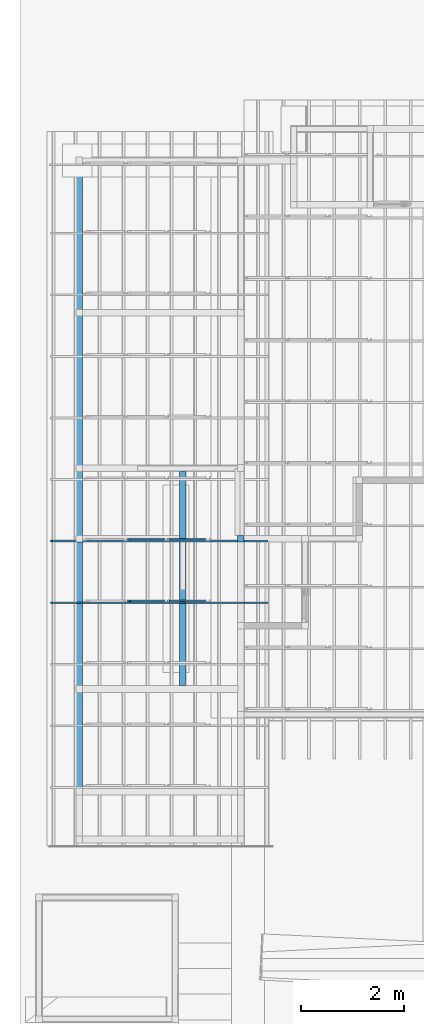
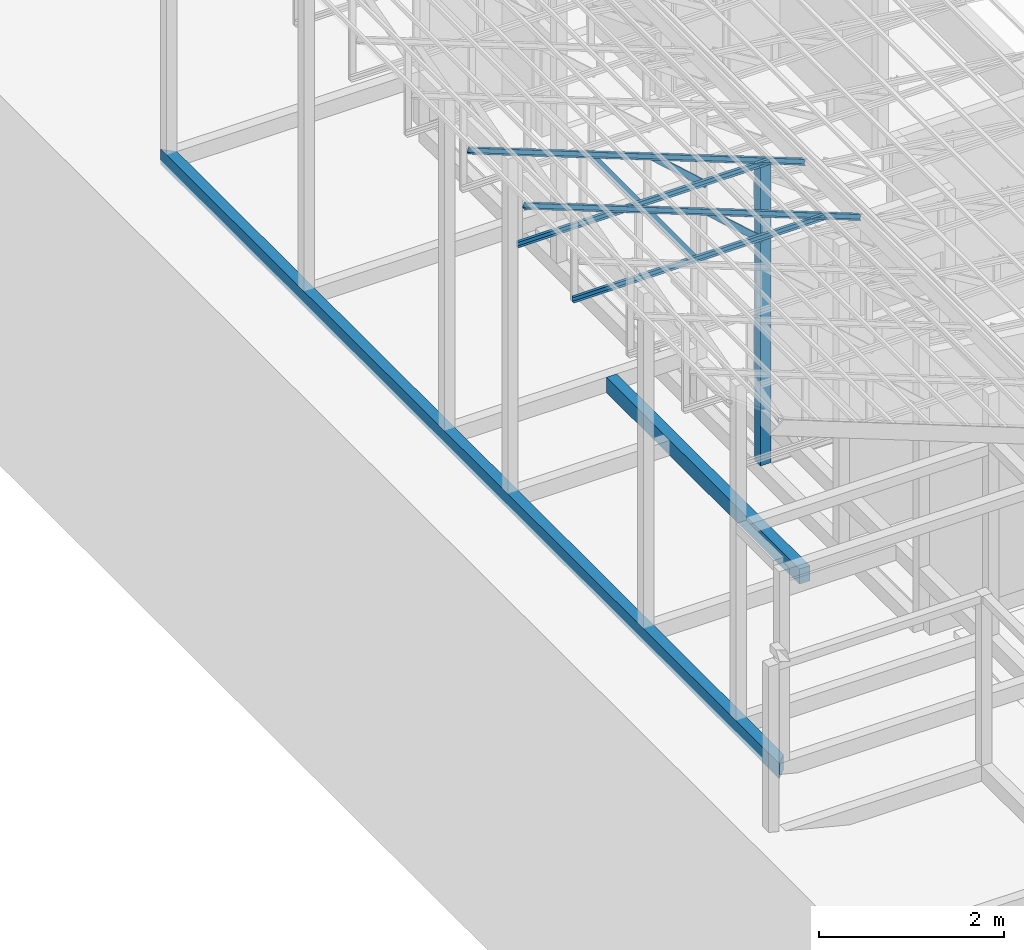
# One storey, part 7 of 22: 8 members, 3 beams, 1 element without a shape of its own.
"""IFC4 building model written with IfcOpenShell, lengths in millimetres."""

from ifc_helpers import new_model, entity, si_unit, converted_unit, frame, origin_with_axes, origin_2d_with_axis, place, context, subcontext, project, spatial, indexed_curve, rectangle, c_section, outline, extrude, clip, halfspace, material, material_profile, profile_set, profile_usage, type_object, element, aggregate, save


model = new_model("IFC4")

# Units and contexts
model_context = context("Model", 3, precision=1e-05, world=origin_with_axes())
plan_context = context("Plan", 2, precision=1e-05, world=origin_2d_with_axis())
body_context = subcontext(model_context, "Body", "Model", "MODEL_VIEW")
ifc_project = project(units=[si_unit("VOLUMEUNIT", "CUBIC_METRE"), si_unit("LENGTHUNIT", "METRE", prefix="MILLI"), si_unit("AREAUNIT", "SQUARE_METRE"), converted_unit("PLANEANGLEUNIT", "degree", entity("IfcReal", 0.0174532925199433), si_unit("PLANEANGLEUNIT", "RADIAN"), dimensions=[0, 0, 0, 0, 0, 0, 0])], contexts=[model_context, plan_context])

# Site, building, storey
site_placement = place(None, origin_with_axes())
site = spatial("IfcSite", under=ifc_project, at=site_placement)
building_placement = place(site_placement, origin_with_axes())
building = spatial("IfcBuilding", under=site, at=building_placement, Name="2")
storey_placement = place(building_placement, frame((0.0, 0.0, 200.000002980232), z_axis=(0.0, 0.0, 1.0), x_axis=(1.0, 0.0, 0.0)))
storey = spatial("IfcBuildingStorey", under=building, at=storey_placement)

# Beams
ifc_material_1 = material(Name="Concrete")
ifc_material_profile_1 = material_profile(ifc_material_1, outline(indexed_curve([(-65.0, 99.9999923706055), (65.0, 99.9999923706055), (65.0, -99.9999923706055), (-65.0, -99.9999923706055), (-65.0, 99.9999923706055)])))
ifc_profile_set_1 = profile_set([ifc_material_profile_1])
ifc_profile_usage_1 = profile_usage(ifc_profile_set_1, cardinal=2)
beam_type_1 = type_object("IfcBeamType", PredefinedType="BEAM", material=ifc_profile_set_1)
beam_1_placement = place(storey_placement, frame((-7149.99485015869, 17365.0016784668, 535.004422068596), z_axis=(-4.03943602122987e-07, -0.999999999999879, -2.82129974493694e-07), x_axis=(0.999999999999919, -4.03943602123003e-07, -2.79054360727867e-14)))
element("IfcBeam", 1, at=beam_1_placement, inside=storey, type_object=beam_type_1, material=ifc_profile_usage_1, Name="Beam", PredefinedType="BEAM", context=body_context, shape_type="Clipping", body=[
    clip(clip(extrude(outline(indexed_curve([(-65.0, 99.9999923706055), (65.0, 99.9999923706055), (65.0, -99.9999923706055), (-65.0, -99.9999923706055), (-65.0, 99.9999923706055)])), frame((0.0, 100.0, 0.0), z_axis=(0.0, 0.0, 1.0), x_axis=(1.0, 0.0, 0.0)), (0.0, 0.0, 1.0), 13364.9967612333), halfspace(frame((-65.0002434849739, -735.001146793365, 13364.9959564209), z_axis=(0.707107067108154, 2.83789603372497e-07, 0.707106471061707), x_axis=(4.01338943666742e-07, -0.99999999999992, 0.0)), False)), halfspace(frame((-64.9999156594276, -735.005497932434, 0.00100710269634874), z_axis=(0.707109093666077, -2.41642055698321e-07, -0.707104444503784), x_axis=(-3.41732354827301e-07, -0.999999999999942, 0.0)), False)),
])
ifc_profile_usage_2 = profile_usage(ifc_profile_set_1, cardinal=3)
beam_2_placement = place(storey_placement, frame((-5064.99624252319, 7065.00005722046, 535.004422068596), z_axis=(3.89414367418746e-07, 0.999999999999875, 3.13916473260139e-07), x_axis=(-0.999999999999924, 3.89414367418765e-07, -7.40532613008271e-09)))
element("IfcBeam", 2, at=beam_2_placement, inside=storey, type_object=beam_type_1, material=ifc_profile_usage_2, Name="Beam", PredefinedType="BEAM", context=body_context, shape_type="SweptSolid", body=[
    extrude(outline(indexed_curve([(-65.0, 99.9999923706055), (65.0, 99.9999923706055), (65.0, -99.9999923706055), (-65.0, -99.9999923706055), (-65.0, 99.9999923706055)])), frame((65.0, 99.9999923706055, 0.0), z_axis=(0.0, 0.0, 1.0), x_axis=(1.0, 0.0, 0.0)), (0.0, 0.0, 1.0), 4170.00443602466),
])
ifc_material_profile_2 = material_profile(ifc_material_1, rectangle(XDim=130.000015258789, YDim=130.000015258789, kind="CURVE"))
ifc_profile_set_2 = profile_set([ifc_material_profile_2])
ifc_profile_usage_3 = profile_usage(ifc_profile_set_2, cardinal=5)
beam_type_2 = type_object("IfcBeamType", PredefinedType="BEAM", material=ifc_profile_set_2)
beam_3_placement = place(storey_placement, frame((-3999.99761581421, 9930.00030517578, 8.94069671630859e-05), z_axis=(0.0, 0.0, 1.0), x_axis=(1.0, 0.0, 0.0)))
element("IfcBeam", 3, at=beam_3_placement, inside=storey, type_object=beam_type_2, material=ifc_profile_usage_3, Name="Column", PredefinedType="BEAM", context=body_context, shape_type="SweptSolid", body=[
    extrude(rectangle(XDim=130.000015258789, YDim=130.000015258789, kind="CURVE"), origin_with_axes(), (0.0, 0.0, 1.0), 3934.94962415235),
])

# Assembly, members
assembly_placement = place(storey_placement, frame((-3938.51041793823, 5099.00283813477, 3935.3459328413), z_axis=(0.0, 0.0, 1.0), x_axis=(1.0, 0.0, 0.0)))
assembly = element("IfcElementAssembly", 4, at=assembly_placement, inside=storey, Name="2")
ifc_material_2 = material(Name="STEEL")
ifc_material_profile_3 = material_profile(ifc_material_2, c_section(Depth=75.0, Width=35.0, WallThickness=1.0, Girth=1.0, kind="CURVE"))
ifc_profile_set_3 = profile_set([ifc_material_profile_3])
ifc_profile_usage_4 = profile_usage(ifc_profile_set_3, cardinal=1)
member_type = type_object("IfcMemberType", Name="C75", PredefinedType="CHORD", material=ifc_profile_set_3)
member_1_placement = place(assembly_placement, frame((3.51285934448242, 3564.9995803833, -1.35517120361328), z_axis=(-0.999999999999812, -4.33125762810878e-07, 4.33125762810878e-07), x_axis=(4.33125762810919e-07, -0.999999999999906, -1.13742348872837e-13)))
member_1 = element("IfcMember", 5, at=member_1_placement, type_object=member_type, material=ifc_profile_usage_4, Name="Member", context=body_context, shape_type="SweptSolid", body=[
    extrude(c_section(Depth=75.0, Width=35.0, WallThickness=1.0, Girth=1.0, kind="CURVE"), frame((-17.5, 37.5, 0.0), z_axis=(0.0, 0.0, 1.0), x_axis=(1.0, 0.0, 0.0)), (0.0, 0.0, 1.0), 3150.02386296032),
])
ifc_profile_usage_5 = profile_usage(ifc_profile_set_3, cardinal=3)
member_2_placement = place(assembly_placement, frame((-2271.51107788086, 3599.99942779541, 894.618034362793), z_axis=(0.578723368640778, -7.49756619914683e-07, -0.815523919078103), x_axis=(1.02917226740772e-06, 0.999999999999453, -1.89020340712783e-07)))
member_2 = element("IfcMember", 6, at=member_2_placement, type_object=member_type, material=ifc_profile_usage_5, Name="Member", context=body_context, shape_type="SweptSolid", body=[
    extrude(c_section(Depth=75.0, Width=35.0, WallThickness=1.0, Girth=1.0, kind="CURVE"), frame((17.5, 37.5, 0.0), z_axis=(0.0, 0.0, 1.0), x_axis=(1.0, 0.0, 0.0)), (0.0, 0.0, 1.0), 1142.30360336039),
])
ifc_profile_usage_6 = profile_usage(ifc_profile_set_3, cardinal=1)
member_3_placement = place(assembly_placement, frame((438.234329223633, 3565.00053405762, -169.034004211426), z_axis=(-0.933001152035968, -8.32115964913738e-07, 0.359873380925658), x_axis=(9.09962921013707e-07, -0.999999999999585, 4.6906695416718e-08)))
member_3 = element("IfcMember", 7, at=member_3_placement, type_object=member_type, material=ifc_profile_usage_6, Name="Member", context=body_context, shape_type="SweptSolid", body=[
    extrude(c_section(Depth=75.0, Width=35.0, WallThickness=1.0, Girth=1.0, kind="CURVE"), frame((-17.5, 37.5, 0.0), z_axis=(0.0, 0.0, 1.0), x_axis=(1.0, 0.0, 0.0)), (0.0, 0.0, 1.0), 4510.0754953159),
])
ifc_profile_usage_7 = profile_usage(ifc_profile_set_3, cardinal=7)
member_4_placement = place(assembly_placement, frame((-1445.26290893555, 3635.96057891846, 624.074935913086), z_axis=(0.745142107017777, -0.00102660805644996, -0.66690493057482), x_axis=(0.00137753843534741, 0.999999051193456, -2.17762747561669e-07)))
member_4 = element("IfcMember", 8, at=member_4_placement, type_object=member_type, material=ifc_profile_usage_7, Name="Member", context=body_context, shape_type="SweptSolid", body=[
    extrude(c_section(Depth=75.0, Width=35.0, WallThickness=1.0, Girth=1.0, kind="CURVE"), frame((-17.5, -37.5, 0.0), z_axis=(0.0, 0.0, 1.0), x_axis=(1.0, 0.0, 0.0)), (0.0, 0.0, 1.0), 937.808496265298),
])
ifc_profile_usage_8 = profile_usage(ifc_profile_set_3, cardinal=1)
member_5_placement = place(assembly_placement, frame((3.51285934448242, 4764.99938964844, -1.35517120361328), z_axis=(-0.999999999999812, -4.33125762810878e-07, 4.33125762810878e-07), x_axis=(4.33125762810919e-07, -0.999999999999906, -1.13742348872837e-13)))
member_5 = element("IfcMember", 9, at=member_5_placement, type_object=member_type, material=ifc_profile_usage_8, Name="Member", context=body_context, shape_type="SweptSolid", body=[
    extrude(c_section(Depth=75.0, Width=35.0, WallThickness=1.0, Girth=1.0, kind="CURVE"), frame((-17.5, 37.5, 0.0), z_axis=(0.0, 0.0, 1.0), x_axis=(1.0, 0.0, 0.0)), (0.0, 0.0, 1.0), 3150.02386296032),
])
ifc_profile_usage_9 = profile_usage(ifc_profile_set_3, cardinal=7)
member_6_placement = place(assembly_placement, frame((-1445.26290893555, 4835.96038818359, 624.074935913086), z_axis=(0.745142107017777, -0.00102660805644996, -0.66690493057482), x_axis=(0.00137753843534741, 0.999999051193456, -2.17762747561669e-07)))
member_6 = element("IfcMember", 10, at=member_6_placement, type_object=member_type, material=ifc_profile_usage_9, Name="Member", context=body_context, shape_type="SweptSolid", body=[
    extrude(c_section(Depth=75.0, Width=35.0, WallThickness=1.0, Girth=1.0, kind="CURVE"), frame((-17.5, -37.5, 0.0), z_axis=(0.0, 0.0, 1.0), x_axis=(1.0, 0.0, 0.0)), (0.0, 0.0, 1.0), 937.808496265298),
])
ifc_profile_usage_10 = profile_usage(ifc_profile_set_3, cardinal=3)
member_7_placement = place(assembly_placement, frame((-2271.51107788086, 4799.99923706055, 894.618034362793), z_axis=(0.578723368640778, -7.49756619914683e-07, -0.815523919078103), x_axis=(1.02917226740772e-06, 0.999999999999453, -1.89020340712783e-07)))
member_7 = element("IfcMember", 11, at=member_7_placement, type_object=member_type, material=ifc_profile_usage_10, Name="Member", context=body_context, shape_type="SweptSolid", body=[
    extrude(c_section(Depth=75.0, Width=35.0, WallThickness=1.0, Girth=1.0, kind="CURVE"), frame((17.5, 37.5, 0.0), z_axis=(0.0, 0.0, 1.0), x_axis=(1.0, 0.0, 0.0)), (0.0, 0.0, 1.0), 1142.30360336039),
])
ifc_profile_usage_11 = profile_usage(ifc_profile_set_3, cardinal=1)
member_8_placement = place(assembly_placement, frame((438.234329223633, 4765.00034332275, -169.034004211426), z_axis=(-0.933001152035968, -8.32115964913738e-07, 0.359873380925658), x_axis=(9.09962921013707e-07, -0.999999999999585, 4.6906695416718e-08)))
member_8 = element("IfcMember", 12, at=member_8_placement, type_object=member_type, material=ifc_profile_usage_11, Name="Member", context=body_context, shape_type="SweptSolid", body=[
    extrude(c_section(Depth=75.0, Width=35.0, WallThickness=1.0, Girth=1.0, kind="CURVE"), frame((-17.5, 37.5, 0.0), z_axis=(0.0, 0.0, 1.0), x_axis=(1.0, 0.0, 0.0)), (0.0, 0.0, 1.0), 4510.0754953159),
])
aggregate(assembly, [member_1, member_2, member_3, member_4, member_5, member_6, member_7, member_8])

save(model, "model.ifc")
